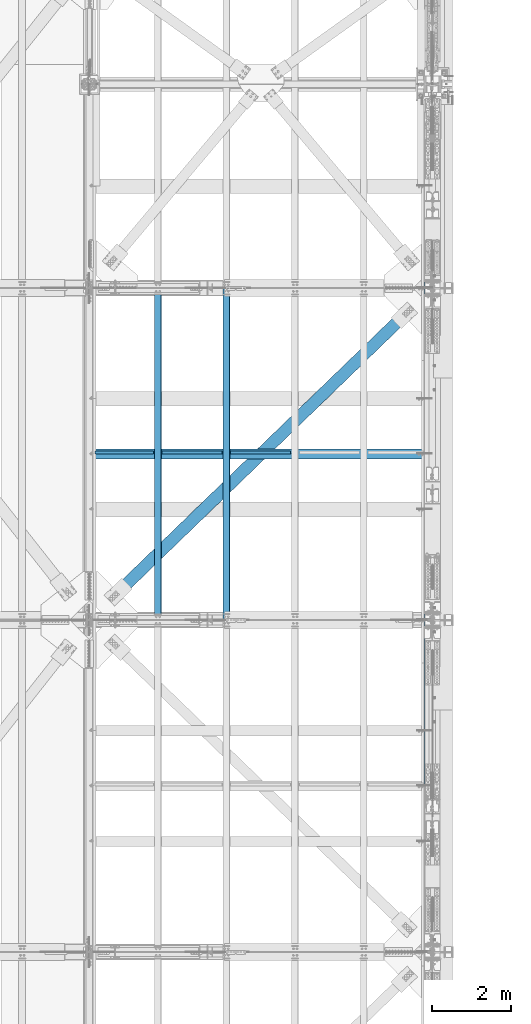
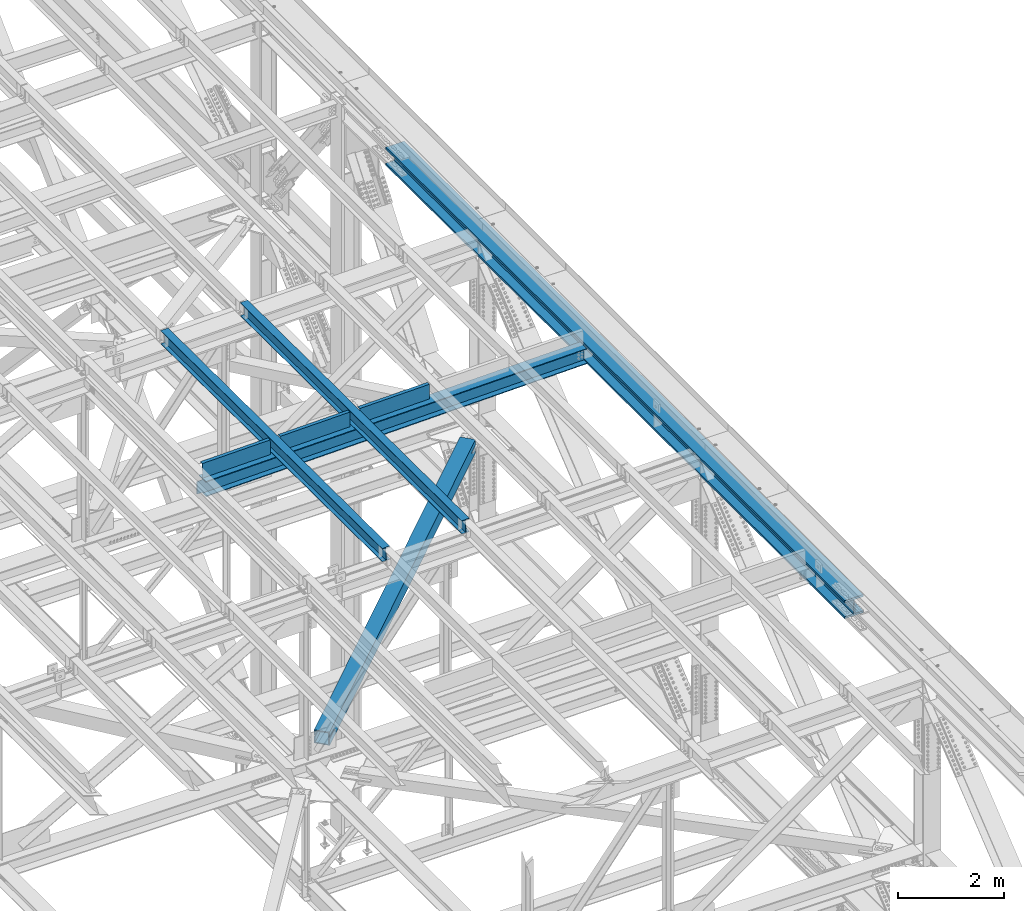
# One storey, part 1982 of 3843: 8 beams, 8 elements without a shape of their own.
"""IFC2X3 building model written with IfcOpenShell, lengths in millimetres."""

from ifc_helpers import new_model, si_unit, frame, origin_with_axes, place, context, subcontext, project, spatial, faceted_brep, material, type_object, element, aggregate, save


model = new_model("IFC2X3")

# Units and contexts
model_context = context("Model", 3, precision=1e-05, world=origin_with_axes())
body_context = subcontext(model_context, "Body", "Model", "MODEL_VIEW")
ifc_project = project(units=[si_unit("LENGTHUNIT", "METRE", prefix="MILLI"), si_unit("AREAUNIT", "SQUARE_METRE"), si_unit("VOLUMEUNIT", "CUBIC_METRE"), si_unit("MASSUNIT", "GRAM", prefix="KILO"), si_unit("TIMEUNIT", "SECOND"), si_unit("PLANEANGLEUNIT", "RADIAN"), si_unit("SOLIDANGLEUNIT", "STERADIAN"), si_unit("THERMODYNAMICTEMPERATUREUNIT", "DEGREE_CELSIUS"), si_unit("LUMINOUSINTENSITYUNIT", "LUMEN")], contexts=[model_context])

# Site, building, storey
site_placement = place(None, origin_with_axes())
site = spatial("IfcSite", under=ifc_project, at=site_placement, CompositionType="ELEMENT")
building_placement = place(site_placement, origin_with_axes())
building = spatial("IfcBuilding", under=site, at=building_placement, Name="Undefined", CompositionType="ELEMENT")
storey_placement = place(building_placement, origin_with_axes())
storey = spatial("IfcBuildingStorey", under=building, at=storey_placement, Name="Undefined", CompositionType="ELEMENT", Elevation=0.0)

# Assembly, beam
assembly_1_placement = place(storey_placement, origin_with_axes())
assembly_1 = element("IfcElementAssembly", 1, at=assembly_1_placement, inside=storey, Name="BEAM", AssemblyPlace="NOTDEFINED", PredefinedType="RIGID_FRAME")
ifc_material_1 = material(Name="STEEL/A992")
beam_type_1 = type_object("IfcBeamType", Name="W12X26", PredefinedType="NOTDEFINED")
beam_1_placement = place(assembly_1_placement, frame((80463.9094956042, 75629.3538179581, 46568.9364390304), z_axis=(-0.0211520978551998, 0.00548814400003175, 0.999761206004593), x_axis=(-2.79999995016577e-08, 0.999984933284011, -0.0054893720015587)))
beam_1 = element("IfcBeam", 2, at=beam_1_placement, type_object=beam_type_1, material=ifc_material_1, Name="BEAM", ObjectType="W12X26", context=body_context, shape_type="Brep", body=[
    faceted_brep([(12.7097787592938, 82.5500000013999, -155.574999999641), (12.6575034070993, 82.5500000013417, -146.049999999654), (8343.98302908371, 82.5499999836029, -146.049999993309), (8344.03530443589, 82.5499999836611, -155.574999993281), (12.6482846770959, 3.17500000093423, -146.049999999646), (8343.97381035371, 3.17499998316634, -146.049999993294), (11.0451738764241, 3.17499999911524, 146.049999999675), (8342.37069955299, 3.17499998134736, 146.05000000602), (11.0543926064129, 82.5499999995372, 146.049999999661), (8342.379918283, 82.5499999817839, 146.050000006013), (11.0021172542038, 82.5499999994936, 155.574999999633), (8342.32764293082, 82.5499999817257, 155.575000005985), (10.9829422958137, -82.5500000014435, 155.574999999662), (8342.3084679724, -82.5500000191823, 155.575000006014), (11.0352176479937, -82.5500000013708, 146.049999999683), (8342.36074332461, -82.5500000191096, 146.050000006042), (11.0444363780116, -3.17500000093423, 146.049999999668), (8342.36996205461, -3.17500001867302, 146.050000006027), (12.6475471787126, -3.17499999911524, -146.049999999639), (8343.9730728553, -3.17500001686858, -146.049999993294), (12.6383284487092, -82.5499999995518, -146.049999999625), (8343.96385412531, -82.5500000172906, -146.04999999328), (12.6906038008892, -82.5499999994936, -155.574999999611), (8344.0161294775, -82.5500000172469, -155.574999993252)], [[[0, 1, 2, 3]], [[1, 4, 5, 2]], [[4, 6, 7, 5]], [[6, 8, 9, 7]], [[8, 10, 11, 9]], [[10, 12, 13, 11]], [[12, 14, 15, 13]], [[14, 16, 17, 15]], [[16, 18, 19, 17]], [[18, 20, 21, 19]], [[20, 22, 23, 21]], [[22, 0, 3, 23]], [[5, 7, 9, 11, 13, 15, 17, 19, 21, 23, 3, 2]], [[22, 20, 18, 16, 14, 12, 10, 8, 6, 4, 1, 0]]]),
])
aggregate(assembly_1, [beam_1])

assembly_2_placement = place(storey_placement, origin_with_axes())
assembly_2 = element("IfcElementAssembly", 3, at=assembly_2_placement, inside=storey, Name="BEAM", AssemblyPlace="NOTDEFINED", PredefinedType="RIGID_FRAME")
beam_2_placement = place(assembly_2_placement, frame((78736.7094955792, 75629.4056891217, 46535.1810461957), z_axis=(-0.0211520977636101, 0.00582156000079706, 0.99975932013628), x_axis=(-2.8000000666196e-08, 0.999983046989539, -0.00582286299993951)))
beam_2 = element("IfcBeam", 4, at=beam_2_placement, type_object=beam_type_1, material=ifc_material_1, Name="BEAM", ObjectType="W12X26", context=body_context, shape_type="Brep", body=[
    faceted_brep([(12.7103851462743, 82.5499999995809, -155.574999999808), (12.6549338504556, 82.5499999996246, -146.049999999806), (8343.99617516747, 82.5499999821041, -146.050000004871), (8344.05162646329, 82.5499999820458, -155.575000004872), (12.6451551801292, 3.174999999188, -146.050000000025), (8343.98639649714, 3.1749999816675, -146.050000005089), (10.944648774981, 3.17500000080327, 146.050000000025), (8342.28589009201, 3.17499998329731, 146.049999994961), (10.9544274453074, 82.5500000012398, 146.050000000243), (8342.29566876232, 82.5499999837193, 146.049999995172), (10.8989761495031, 82.550000001298, 155.575000000244), (8342.2402174665, 82.5499999837775, 155.57499999518), (10.8786365152046, -82.54999999961, 155.574999999786), (8342.21987783222, -82.5500000171305, 155.574999994729), (10.9340878110379, -82.5499999996537, 146.049999999792), (8342.27532912804, -82.5500000171887, 146.049999994728), (10.9438664813642, -3.17499999921711, 146.05000000001), (8342.28510779837, -3.17500001675216, 146.049999994939), (12.6443728864979, -3.17500000083237, -146.050000000047), (8343.98561420353, -3.17500001838198, -146.050000005103), (12.634594216157, -82.5500000012835, -146.050000000265), (8343.9758355332, -82.5500000187894, -146.050000005322), (12.6900455119903, -82.5500000013271, -155.575000000259), (8344.03128682902, -82.5500000188476, -155.575000005323)], [[[0, 1, 2, 3]], [[1, 4, 5, 2]], [[4, 6, 7, 5]], [[6, 8, 9, 7]], [[8, 10, 11, 9]], [[10, 12, 13, 11]], [[12, 14, 15, 13]], [[14, 16, 17, 15]], [[16, 18, 19, 17]], [[18, 20, 21, 19]], [[20, 22, 23, 21]], [[22, 0, 3, 23]], [[5, 7, 9, 11, 13, 15, 17, 19, 21, 23, 3, 2]], [[22, 20, 18, 16, 14, 12, 10, 8, 6, 4, 1, 0]]]),
])
aggregate(assembly_2, [beam_2])

assembly_3_placement = place(storey_placement, origin_with_axes())
assembly_3 = element("IfcElementAssembly", 5, at=assembly_3_placement, inside=storey, Name="BENT_PLATE", AssemblyPlace="NOTDEFINED", PredefinedType="RIGID_FRAME")
ifc_material_2 = material(Name="STEEL/A36")
beam_type_2 = type_object("IfcBeamType", PredefinedType="NOTDEFINED")
beam_3_placement = place(assembly_3_placement, frame((77895.8502140267, 79811.5625000033, 46316.359233359), z_axis=(-0.999817430718778, 0.0, -0.0191077269946473), x_axis=(-0.0191077269946443, 0.0, 0.999817430718778)))
beam_3 = element("IfcBeam", 6, at=beam_3_placement, type_object=beam_type_2, material=ifc_material_2, Name="BENT_PLATE", context=body_context, shape_type="Brep", body=[
    faceted_brep([(2.31375452131033e-09, -4.76249999999709, -736.599999997517), (-2.30647856369615e-09, -4.76249999999709, 736.599999997474), (-2.30647856369615e-09, 4.76249999999709, 736.599999997474), (2.31375452131033e-09, 4.76249999999709, -736.599999997517), (327.024999947338, 4.76250000002619, 736.600000004051), (327.024999981979, 4.76250000002619, -736.600000004313), (336.549999981966, -4.76249999996799, -736.600000004328), (336.549999947325, -4.76249999996799, 736.600000004051), (327.024999959613, 71.4375000200889, 736.600000005245), (327.024999969712, 71.4375000446889, -736.60000000312), (336.549999959585, 71.4375000200962, 736.600000005245), (336.549999969691, 71.4375000446962, -736.600000003134)], [[[0, 1, 2, 3]], [[3, 2, 4, 5]], [[1, 0, 6, 7]], [[5, 4, 8, 9]], [[4, 2, 1, 7, 10, 8]], [[7, 6, 11, 10]], [[6, 0, 3, 5, 9, 11]], [[10, 11, 9, 8]]]),
])
aggregate(assembly_3, [beam_3])

assembly_4_placement = place(storey_placement, origin_with_axes())
assembly_4 = element("IfcElementAssembly", 7, at=assembly_4_placement, inside=storey, Name="BENT_PLATE", AssemblyPlace="NOTDEFINED", PredefinedType="RIGID_FRAME")
beam_4_placement = place(assembly_4_placement, frame((79603.8052549715, 79811.5625000034, 46349.0041236298), z_axis=(-0.999817430718778, 0.0, -0.0191077269946473), x_axis=(-0.0191077269946443, 0.0, 0.999817430718778)))
beam_4 = element("IfcBeam", 8, at=beam_4_placement, type_object=beam_type_2, material=ifc_material_2, Name="BENT_PLATE", context=body_context, shape_type="Brep", body=[
    faceted_brep([(2.38651409745216e-09, -4.76249999999709, -755.649999997448), (-2.37923813983798e-09, -4.76249999999709, 755.649999997433), (-2.37923813983798e-09, 4.76249999999709, 755.649999997433), (2.38651409745216e-09, 4.76249999999709, -755.649999997448), (327.024999945941, 4.76250000002619, 755.650000004171), (327.024999981295, 4.76250000002619, -755.650000004418), (336.549999981282, -4.76249999996799, -755.650000004447), (336.549999945928, -4.76249999996799, 755.650000004156), (327.024999958514, 71.4375000207219, 755.650000005364), (327.024999968708, 71.4375000458094, -755.650000003239), (336.549999958501, 71.4375000207219, 755.650000005349), (336.549999968687, 71.4375000458094, -755.650000003254)], [[[0, 1, 2, 3]], [[3, 2, 4, 5]], [[1, 0, 6, 7]], [[5, 4, 8, 9]], [[4, 2, 1, 7, 10, 8]], [[7, 6, 11, 10]], [[6, 0, 3, 5, 9, 11]], [[10, 11, 9, 8]]]),
])
aggregate(assembly_4, [beam_4])

assembly_5_placement = place(storey_placement, origin_with_axes())
assembly_5 = element("IfcElementAssembly", 9, at=assembly_5_placement, inside=storey, Name="BENT_PLATE", AssemblyPlace="NOTDEFINED", PredefinedType="RIGID_FRAME")
beam_5_placement = place(assembly_5_placement, frame((81330.8068169715, 79811.5625000034, 46382.6083280998), z_axis=(-0.999817430718778, 0.0, -0.0191077269946473), x_axis=(-0.0191077269946443, 0.0, 0.999817430718778)))
beam_5 = element("IfcBeam", 10, at=beam_5_placement, type_object=beam_type_2, material=ifc_material_2, Name="BENT_PLATE", context=body_context, shape_type="Brep", body=[
    faceted_brep([(2.38651409745216e-09, -4.76249999999709, -755.649999997448), (-2.37923813983798e-09, -4.76249999999709, 755.649999997433), (-2.37923813983798e-09, 4.76249999999709, 755.649999997433), (2.38651409745216e-09, 4.76249999999709, -755.649999997448), (327.024999945941, 4.76250000002619, 755.650000004171), (327.024999981295, 4.76250000002619, -755.650000004418), (336.549999981282, -4.76249999996799, -755.650000004447), (336.549999945928, -4.76249999996799, 755.650000004156), (327.024999958514, 71.4375000207219, 755.650000005364), (327.024999968708, 71.4375000458094, -755.650000003239), (336.549999958501, 71.4375000207219, 755.650000005349), (336.549999968687, 71.4375000458094, -755.650000003254)], [[[0, 1, 2, 3]], [[3, 2, 4, 5]], [[1, 0, 6, 7]], [[5, 4, 8, 9]], [[4, 2, 1, 7, 10, 8]], [[7, 6, 11, 10]], [[6, 0, 3, 5, 9, 11]], [[10, 11, 9, 8]]]),
])
aggregate(assembly_5, [beam_5])

assembly_6_placement = place(storey_placement, origin_with_axes())
assembly_6 = element("IfcElementAssembly", 11, at=assembly_6_placement, inside=storey, Name="BEAM", AssemblyPlace="NOTDEFINED", PredefinedType="RIGID_FRAME")
beam_type_3 = type_object("IfcBeamType", Name="W14X257", PredefinedType="NOTDEFINED")
beam_6_placement = place(assembly_6_placement, frame((85648.8, 70014.7142968034, 46314.5491930665), z_axis=(0.0, 0.00329764299921226, 0.999994562760543), x_axis=(0.0, 0.999994562760543, -0.00329764299921044)))
beam_6 = element("IfcBeam", 12, at=beam_6_placement, type_object=beam_type_3, material=ifc_material_1, Name="BEAM", ObjectType="W14X257", context=body_context, shape_type="Brep", body=[
    faceted_brep([(13817.3349582041, -203.199999999997, 164.32508028848), (13817.3349582041, -15.0812500000029, 164.32508028848), (15544.5303172543, -15.0812500000029, 162.580440755861), (15544.5303172543, -203.199999999997, 162.580440755861), (12090.1391675801, -203.199999999997, 165.571251487934), (12090.1391675801, -15.0812500000029, 165.571251487934), (10362.9430892403, -203.199999999997, 166.318954250833), (10362.9430892403, -15.0812500000029, 166.318954250833), (8635.74686704262, -203.199999999997, 166.568188513855), (8635.74686704262, -15.0812500000029, 166.568188513855), (6908.5506448449, -203.199999999997, 166.318954257426), (6908.5506448449, -15.0812500000029, 166.318954257426), (5181.35456650514, -203.199999999997, 165.571251501126), (5181.35456650514, -15.0812500000029, 165.571251501126), (3454.15877588118, -203.199999999997, 164.325080308277), (3454.15877588118, -15.0812500000029, 164.325080308277), (1726.96341683094, -203.199999999997, 162.580440782258), (1726.96341683094, -15.0812500000029, 162.580440782258), (6.11862910160562, -203.199999999997, 160.345579806541), (6.11862910160562, -15.0812500000029, 160.345579806541), (13817.3349582041, 15.0812500000029, 164.32508028848), (13817.3349582041, 203.199999999997, 164.32508028848), (15544.5303172543, 203.199999999997, 162.580440755861), (15544.5303172543, 15.0812500000029, 162.580440755861), (12090.1391675801, 15.0812500000029, 165.571251487934), (12090.1391675801, 203.199999999997, 165.571251487934), (10362.9430892403, 15.0812500000029, 166.318954250833), (10362.9430892403, 203.199999999997, 166.318954250833), (8635.74686704262, 15.0812500000029, 166.568188513855), (8635.74686704262, 203.199999999997, 166.568188513855), (6908.5506448449, 15.0812500000029, 166.318954257426), (6908.5506448449, 203.199999999997, 166.318954257426), (5181.35456650514, 15.0812500000029, 165.571251501126), (5181.35456650514, 203.199999999997, 165.571251501126), (3454.15877588118, 15.0812500000029, 164.325080308277), (3454.15877588118, 203.199999999997, 164.325080308277), (1726.96341683094, 15.0812500000029, 162.580440782258), (1726.96341683094, 203.199999999997, 162.580440782258), (6.11862910160562, 15.0812500000029, 160.345579806541), (6.11862910160562, 203.199999999997, 160.345579806541), (13817.0573179999, 203.199999999997, -156.349799519972), (13817.0573179999, 15.0812500000029, -156.349799519972), (15544.1601303508, 15.0812500000029, -158.094345571204), (15544.1601303508, 203.199999999997, -158.094345571204), (12089.9540740984, 203.199999999997, -155.103695092948), (12089.9540740984, 15.0812500000029, -155.103695092948), (10362.8505424965, 203.199999999997, -154.356032393509), (10362.8505424965, 15.0812500000029, -154.356032393509), (8635.74686704433, 203.199999999997, -154.106811484977), (8635.74686704433, 15.0812500000029, -154.106811484977), (6908.64319159219, 203.199999999997, -154.356032386917), (6908.64319159219, 15.0812500000029, -154.356032386917), (5181.53965999027, 203.199999999997, -155.10369507975), (5181.53965999027, 15.0812500000029, -155.10369507975), (3454.43641608878, 203.199999999997, -156.349799500167), (3454.43641608878, 15.0812500000029, -156.349799500167), (1727.33360373788, 203.199999999997, -158.094345544807), (1727.33360373788, 15.0812500000029, -158.094345544807), (6.58136037488293, 203.199999999997, -160.329086333157), (6.58136037488293, 15.0812500000029, -160.329086333157), (13817.0160843062, -203.199999999997, -203.974781669742), (13817.0160843062, 203.199999999997, -203.974781669742), (15544.1051520978, 203.199999999997, -205.719313837588), (15544.1051520978, -203.199999999997, -205.719313837588), (12089.9265849674, -203.199999999997, -202.728687159419), (12089.9265849674, 203.199999999997, -202.728687159419), (10362.8367979305, -203.199999999997, -201.981030409996), (10362.8367979305, 203.199999999997, -201.981030409996), (8635.74686704458, -203.199999999997, -201.731811484802), (8635.74686704458, 203.199999999997, -201.731811484802), (6908.65693615862, -203.199999999997, -201.981030403396), (6908.65693615862, 203.199999999997, -201.981030403396), (5181.56714912175, -203.199999999997, -202.72868714622), (5181.56714912175, 203.199999999997, -202.72868714622), (3454.47764978299, -203.199999999997, -203.974781649944), (3454.47764978299, 203.199999999997, -203.974781649944), (1727.3885819914, -203.199999999997, -205.719313811198), (1727.3885819914, 203.199999999997, -205.719313811198), (6.65008284120995, -203.199999999997, -207.95403674995), (6.65008284120995, 203.199999999997, -207.95403674995), (13817.0573179999, -15.0812500000029, -156.349799519972), (13817.0573179999, -203.199999999997, -156.349799519972), (15544.1601303508, -203.199999999997, -158.094345571204), (15544.1601303508, -15.0812500000029, -158.094345571204), (12089.9540740984, -15.0812500000029, -155.103695092948), (12089.9540740984, -203.199999999997, -155.103695092948), (10362.8505424965, -15.0812500000029, -154.356032393509), (10362.8505424965, -203.199999999997, -154.356032393509), (8635.74686704433, -15.0812500000029, -154.106811484977), (8635.74686704433, -203.199999999997, -154.106811484977), (6908.64319159219, -15.0812500000029, -154.356032386917), (6908.64319159219, -203.199999999997, -154.356032386917), (5181.53965999027, -15.0812500000029, -155.10369507975), (5181.53965999027, -203.199999999997, -155.10369507975), (3454.43641608878, -15.0812500000029, -156.349799500167), (3454.43641608878, -203.199999999997, -156.349799500167), (1727.33360373788, -15.0812500000029, -158.094345544807), (1727.33360373788, -203.199999999997, -158.094345544807), (6.58136037488293, -15.0812500000029, -160.329086333157), (6.58136037488293, -203.199999999997, -160.329086333157), (6.04990663529315, -203.199999999997, 207.970530223327), (6.04990663529315, 203.199999999997, 207.970530223327), (1726.90843857745, -203.199999999997, 210.205409048656), (1726.90843857745, 203.199999999997, 210.205409048656), (3454.11754218697, -203.199999999997, 211.950062458054), (3454.11754218697, 203.199999999997, 211.950062458054), (5181.32707737367, -203.199999999997, 213.196243567589), (5181.32707737367, 203.199999999997, 213.196243567589), (6908.53690027847, -203.199999999997, 213.943952273912), (6908.53690027847, 203.199999999997, 213.943952273912), (8635.74686704236, -203.199999999997, 214.193188513673), (8635.74686704236, 203.199999999997, 214.193188513673), (10362.9568338062, -203.199999999997, 213.94395226732), (10362.9568338062, 203.199999999997, 213.94395226732), (12090.1666567111, -203.199999999997, 213.196243554397), (12090.1666567111, 203.199999999997, 213.196243554397), (13817.3761918978, -203.199999999997, 211.950062438249), (13817.3761918978, 203.199999999997, 211.950062438249), (15544.5852955073, -203.199999999997, 210.205409022252), (15544.5852955073, 203.199999999997, 210.205409022252), (17265.4438341366, -203.199999999997, 207.970530181665), (17265.4438341366, 203.199999999997, 207.970530181665), (17265.374987089, 203.199999999997, 160.345579926674), (17265.374987089, 15.0812500000029, 160.345579926674), (17264.9114169685, 15.0812500000029, -160.329085123609), (17264.9114169685, 203.199999999997, -160.329085123609), (17264.8425699209, 203.199999999997, -207.954035378607), (17264.8425699209, -203.199999999997, -207.954035378607), (17264.9114169685, -203.199999999997, -160.329085123609), (17264.9114169685, -15.0812500000029, -160.329085123609), (17265.374987089, -15.0812500000029, 160.345579926674), (17265.374987089, -203.199999999997, 160.345579926674)], [[[0, 1, 2, 3]], [[4, 5, 1, 0]], [[6, 7, 5, 4]], [[8, 9, 7, 6]], [[10, 11, 9, 8]], [[12, 13, 11, 10]], [[14, 15, 13, 12]], [[16, 17, 15, 14]], [[17, 16, 18, 19]], [[20, 21, 22, 23]], [[24, 25, 21, 20]], [[26, 27, 25, 24]], [[28, 29, 27, 26]], [[30, 31, 29, 28]], [[32, 33, 31, 30]], [[34, 35, 33, 32]], [[36, 37, 35, 34]], [[37, 36, 38, 39]], [[40, 41, 42, 43]], [[44, 45, 41, 40]], [[46, 47, 45, 44]], [[48, 49, 47, 46]], [[50, 51, 49, 48]], [[52, 53, 51, 50]], [[54, 55, 53, 52]], [[56, 57, 55, 54]], [[57, 56, 58, 59]], [[60, 61, 62, 63]], [[64, 65, 61, 60]], [[66, 67, 65, 64]], [[68, 69, 67, 66]], [[70, 71, 69, 68]], [[72, 73, 71, 70]], [[74, 75, 73, 72]], [[76, 77, 75, 74]], [[77, 76, 78, 79]], [[80, 81, 82, 83]], [[84, 85, 81, 80]], [[86, 87, 85, 84]], [[88, 89, 87, 86]], [[90, 91, 89, 88]], [[92, 93, 91, 90]], [[94, 95, 93, 92]], [[96, 97, 95, 94]], [[97, 96, 98, 99]], [[19, 18, 100, 101, 39, 38, 59, 58, 79, 78, 99, 98]], [[102, 103, 101, 100]], [[103, 102, 104, 105]], [[105, 104, 106, 107]], [[107, 106, 108, 109]], [[109, 108, 110, 111]], [[111, 110, 112, 113]], [[113, 112, 114, 115]], [[115, 114, 116, 117]], [[117, 116, 118, 119]], [[119, 118, 120, 121]], [[22, 21, 25, 27, 29, 31, 33, 35, 37, 39, 101, 103, 105, 107, 109, 111, 113, 115, 117, 119, 121, 122]], [[23, 22, 122, 123]], [[42, 41, 45, 47, 49, 51, 53, 55, 57, 59, 38, 36, 34, 32, 30, 28, 26, 24, 20, 23, 123, 124]], [[43, 42, 124, 125]], [[62, 61, 65, 67, 69, 71, 73, 75, 77, 79, 58, 56, 54, 52, 50, 48, 46, 44, 40, 43, 125, 126]], [[63, 62, 126, 127]], [[82, 81, 85, 87, 89, 91, 93, 95, 97, 99, 78, 76, 74, 72, 70, 68, 66, 64, 60, 63, 127, 128]], [[83, 82, 128, 129]], [[2, 1, 5, 7, 9, 11, 13, 15, 17, 19, 98, 96, 94, 92, 90, 88, 86, 84, 80, 83, 129, 130]], [[3, 2, 130, 131]], [[118, 116, 114, 112, 110, 108, 106, 104, 102, 100, 18, 16, 14, 12, 10, 8, 6, 4, 0, 3, 131, 120]], [[130, 129, 128, 127, 126, 125, 124, 123, 122, 121, 120, 131]]]),
])
aggregate(assembly_6, [beam_6])

assembly_7_placement = place(storey_placement, origin_with_axes())
assembly_7 = element("IfcElementAssembly", 13, at=assembly_7_placement, inside=storey, AssemblyPlace="NOTDEFINED", PredefinedType="RIGID_FRAME")
ifc_material_3 = material()
beam_type_4 = type_object("IfcBeamType", Name="HSS12X12X3/4", PredefinedType="NOTDEFINED")
beam_7_placement = place(assembly_7_placement, frame((77012.800003582, 75628.5000028864, 42246.55), z_axis=(0.695386218410511, -0.718636213424239, 0.0), x_axis=(0.718636212924514, 0.695386218926945, 0.0)))
beam_7 = element("IfcBeam", 14, at=beam_7_placement, type_object=beam_type_4, material=ifc_material_3, ObjectType="HSS12X12X3/4", context=body_context, shape_type="Brep", body=[
    faceted_brep([(10999.1862260432, 26.9875000000029, 152.399999948059), (10746.7737266535, 26.9875000000029, 152.399999949274), (10746.7737266534, 26.9875000000029, 133.349999949206), (10999.1862260432, 26.9875000000029, 133.349999947998), (10741.3061369675, 25.8999287917177, 152.399999949296), (10741.3061369674, 25.8999287917177, 133.349999949221), (10736.6709382474, 22.8027880244772, 152.399999949311), (10736.6709382473, 22.8027880244772, 133.34999994925), (10733.5737974801, 18.1675893044303, 152.39999994934), (10733.5737974801, 18.1675893044303, 133.349999949271), (10732.4862262719, 12.6999996185332, 152.399999949347), (10732.4862262718, 12.6999996185332, 133.349999949271), (10733.5737974801, 7.23241069557844, 152.39999994934), (10733.5737974801, 7.23241069557844, 133.349999949271), (10736.6709382474, 2.59721197553154, 152.399999949311), (10736.6709382473, 2.59721197553154, 133.34999994925), (10741.3061369675, -0.499928791708953, 152.399999949296), (10741.3061369674, -0.499928791708953, 133.349999949221), (10746.7737266535, -1.58749999999418, 152.399999949274), (10746.7737266534, -1.58749999999418, 133.349999949206), (10999.1862260432, -1.58749999999418, 152.399999948059), (10999.1862260432, -1.58749999999418, 133.349999947998), (10999.1862260432, 26.9875000000029, -133.350000052945), (10746.7737266521, 26.9875000000029, -133.350000051737), (10746.773726652, 26.9875000000029, -152.400000051798), (10999.1862260432, 26.9875000000029, -152.400000052999), (10741.3061369661, 25.8999287917177, -133.350000051708), (10741.3061369661, 25.8999287917177, -152.400000051769), (10736.6709382461, 22.8027880244772, -133.350000051686), (10736.670938246, 22.8027880244772, -152.400000051762), (10733.5737974788, 18.1675893044303, -133.350000051679), (10733.5737974787, 18.1675893044303, -152.40000005174), (10732.4862262705, 12.6999996185332, -133.350000051671), (10732.4862262704, 12.6999996185332, -152.400000051733), (10733.5737974788, 7.23241069557844, -133.350000051679), (10733.5737974787, 7.23241069557844, -152.40000005174), (10736.6709382461, 2.59721197553154, -133.350000051686), (10736.670938246, 2.59721197553154, -152.400000051762), (10741.3061369661, -0.499928791708953, -133.350000051708), (10741.3061369661, -0.499928791708953, -152.400000051769), (10746.7737266521, -1.58749999999418, -133.350000051737), (10746.773726652, -1.58749999999418, -152.400000051798), (10999.1862260432, -1.58749999999418, -133.350000052945), (10999.1862260432, -1.58749999999418, -152.400000052999), (1326.70066549764, -0.49930169347499, -133.350000006808), (1326.70066548402, -0.49930169347499, -152.400000006869), (1321.23307579808, -1.58687290176022, -152.400000006847), (1321.2330758117, -1.58687290176022, -133.350000006786), (1331.33586421773, 2.5978390737655, -133.35000000683), (1331.33586420411, 2.5978390737655, -152.400000006898), (1334.433004985, 7.2330377938124, -133.350000006837), (1334.43300497139, 7.2330377938124, -152.400000006905), (1335.5205761933, 12.7006267167671, -133.350000006837), (1335.52057617968, 12.7006267167671, -152.400000006913), (1334.433004985, 18.1682164026643, -133.350000006837), (1334.43300497139, 18.1682164026643, -152.400000006905), (1331.33586421773, 22.8034151227112, -133.35000000683), (1331.33586420411, 22.8034151227112, -152.400000006898), (1326.70066549764, 25.9005558899516, -133.350000006808), (1326.70066548402, 25.9005558899516, -152.400000006869), (1321.2330758117, 26.9881270982369, -133.350000006786), (1321.23307579808, 26.9881270982369, -152.400000006847), (1018.02056396882, 26.9881270982369, -133.350000005331), (1018.02056395514, 26.9881270982369, -152.400000005399), (10999.1862260432, -152.400000000001, -152.400000052999), (1018.02056852015, -152.400000000001, -152.399999995658), (1018.02056395514, -1.58687290176022, -152.400000005399), (1018.02056852015, 152.400000000001, -152.399999995658), (10999.1862260432, 152.400000000001, -152.400000052999), (1018.02056396882, -1.58687290176022, -133.350000005331), (10999.1862260432, -133.349999999999, 133.349999947998), (10999.1862260432, -133.349999999999, -133.350000052945), (1018.02056852025, -133.349999999999, -133.349999995713), (1018.02056852159, -133.349999999999, 133.350000003455), (10999.1862260432, 133.349999999999, -133.350000052945), (1018.02056852025, 133.349999999999, -133.349999995713), (10999.1862260432, 133.349999999999, 133.349999947998), (1018.02056852159, 133.349999999999, 133.350000003455), (1326.70066570192, -0.49930169347499, 152.399999994203), (1326.7006656883, -0.49930169347499, 133.349999994135), (1321.23307600235, -1.58687290176022, 133.349999994157), (1321.23307601597, -1.58687290176022, 152.399999994225), (1331.33586442198, 2.5978390737655, 152.399999994174), (1331.33586440836, 2.5978390737655, 133.349999994113), (1334.43300518928, 7.2330377938124, 152.399999994174), (1334.43300517564, 7.2330377938124, 133.349999994099), (1335.52057639755, 12.7006267167671, 152.399999994167), (1335.52057638395, 12.7006267167671, 133.349999994091), (1334.43300518928, 18.1682164026643, 152.399999994174), (1334.43300517564, 18.1682164026643, 133.349999994099), (1331.33586442198, 22.8034151227112, 152.399999994174), (1331.33586440836, 22.8034151227112, 133.349999994113), (1326.70066570192, 25.9005558899516, 152.399999994203), (1326.7006656883, 25.9005558899516, 133.349999994135), (1321.23307601597, 26.9881270982369, 152.399999994225), (1321.23307600235, 26.9881270982369, 133.349999994157), (1018.02056417418, 26.9881270982369, 152.399999995673), (1018.0205641605, 26.9881270982369, 133.349999995605), (1018.02056852169, 152.400000000001, 152.400000003399), (10999.1862260432, 152.400000000001, 152.399999948059), (1018.0205641605, -1.58687290176022, 133.349999995605), (1018.02056417418, -1.58687290176022, 152.399999995673), (1018.02056852169, -152.400000000001, 152.400000003399), (10999.1862260432, -152.400000000001, 152.399999948059)], [[[0, 1, 2, 3]], [[4, 5, 2, 1]], [[6, 7, 5, 4]], [[8, 9, 7, 6]], [[10, 11, 9, 8]], [[12, 13, 11, 10]], [[14, 15, 13, 12]], [[16, 17, 15, 14]], [[18, 19, 17, 16]], [[20, 21, 19, 18]], [[22, 23, 24, 25]], [[26, 27, 24, 23]], [[28, 29, 27, 26]], [[30, 31, 29, 28]], [[32, 33, 31, 30]], [[34, 35, 33, 32]], [[36, 37, 35, 34]], [[38, 39, 37, 36]], [[40, 41, 39, 38]], [[42, 43, 41, 40]], [[44, 45, 46, 47]], [[48, 49, 45, 44]], [[50, 51, 49, 48]], [[52, 53, 51, 50]], [[54, 55, 53, 52]], [[56, 57, 55, 54]], [[58, 59, 57, 56]], [[60, 61, 59, 58]], [[62, 63, 61, 60]], [[64, 65, 66, 46, 45, 49, 51, 53, 55, 57, 59, 61, 63, 67, 68, 25, 24, 27, 29, 31, 33, 35, 37, 39, 41, 43]], [[47, 46, 66, 69]], [[70, 71, 72, 73]], [[38, 36, 34, 32, 30, 28, 26, 23, 22, 74, 75, 62, 60, 58, 56, 54, 52, 50, 48, 44, 47, 69, 72, 71, 42, 40]], [[74, 76, 77, 75]], [[78, 79, 80, 81]], [[82, 83, 79, 78]], [[84, 85, 83, 82]], [[86, 87, 85, 84]], [[88, 89, 87, 86]], [[90, 91, 89, 88]], [[92, 93, 91, 90]], [[94, 95, 93, 92]], [[96, 97, 95, 94]], [[98, 67, 63, 62, 75, 77, 97, 96]], [[99, 68, 67, 98]], [[76, 74, 22, 25, 68, 99, 0, 3]], [[70, 73, 100, 80, 79, 83, 85, 87, 89, 91, 93, 95, 97, 77, 76, 3, 2, 5, 7, 9, 11, 13, 15, 17, 19, 21]], [[81, 80, 100, 101]], [[73, 72, 69, 66, 65, 102, 101, 100]], [[64, 103, 102, 65]], [[16, 14, 12, 10, 8, 6, 4, 1, 0, 99, 98, 96, 94, 92, 90, 88, 86, 84, 82, 78, 81, 101, 102, 103, 20, 18]], [[103, 64, 43, 42, 71, 70, 21, 20]]]),
])
aggregate(assembly_7, [beam_7])

assembly_8_placement = place(storey_placement, origin_with_axes())
assembly_8 = element("IfcElementAssembly", 15, at=assembly_8_placement, inside=storey, Name="BEAM", AssemblyPlace="NOTDEFINED", PredefinedType="RIGID_FRAME")
beam_type_5 = type_object("IfcBeamType", Name="W14X61", PredefinedType="NOTDEFINED")
beam_8_placement = place(assembly_8_placement, frame((77012.7999994625, 79806.8, 46123.2669268797), z_axis=(-0.0191089640014834, 0.0, 0.999817407077307), x_axis=(0.999817407077307, 0.0, 0.0191089640014779)))
beam_8 = element("IfcBeam", 16, at=beam_8_placement, type_object=beam_type_5, material=ifc_material_1, Name="BEAM", ObjectType="W14X61", context=body_context, shape_type="Brep", body=[
    faceted_brep([(15.4985517516616, -4.76249999999709, -144.462499984227), (15.4985517516616, 4.76249999999709, -144.462499984227), (129.191731535015, 4.76249999999709, -144.462499984482), (129.191731535015, -4.76249999999709, -144.462499984482), (134.051811053068, 4.76249999999709, -145.42922990708), (134.051811053068, -4.76249999999709, -145.42922990708), (138.171987521244, 4.76249999999709, -148.182243807583), (138.171987521244, -4.76249999999709, -148.182243807583), (140.92500142171, 4.76249999999709, -152.302420275766), (140.92500142171, -4.76249999999709, -152.302420275766), (141.89173134428, -4.76249999999709, -157.162499793827), (141.89173134428, 4.76249999999709, -157.162499793827), (141.891731344294, 4.76249999999709, -160.337500000533), (141.891731344294, 127.0, -160.337500000533), (141.891731344251, 127.0, -176.212500000569), (141.891731344251, -127.0, -176.212500000569), (141.891731344294, -127.0, -160.337500000533), (141.891731344294, -4.76249999999709, -160.337500000533), (8418.2698977901, -127.0, 160.33749997618), (8418.26989778999, -127.0, 176.21249997618), (141.891731345037, -127.0, 176.212499999958), (141.891731344993, -127.0, 160.337499999929), (8418.26989778999, 127.0, 176.21249997618), (141.891731345037, 127.0, 176.212499999958), (8418.2698977901, 127.0, 160.33749997618), (141.891731344993, 127.0, 160.337499999929), (8418.2698977901, 4.76249999999709, 160.33749997618), (141.891731344993, 4.76249999999709, 160.337499999929), (129.191731535626, -4.76249999999709, 144.462500016787), (129.191731535626, 4.76249999999709, 144.462500016787), (21.0206174659397, 4.76249999999709, 144.462500017027), (21.0206174659397, -4.76249999999709, 144.462500017027), (134.051811053709, -4.76249999999709, 145.429229939371), (134.051811053709, 4.76249999999709, 145.429229939371), (138.171987521884, -4.76249999999709, 148.182243839845), (138.171987521884, 4.76249999999709, 148.182243839845), (140.92500142238, -4.76249999999709, 152.302420308013), (140.92500142238, 4.76249999999709, 152.302420308013), (141.891731344993, -4.76249999999709, 157.162499826074), (141.891731344993, 4.76249999999709, 157.162499826074), (141.891731344993, -4.76249999999709, 160.337499999929), (8418.2698977901, -4.76249999999709, 160.33749997618), (8418.26989779246, 4.76249999999709, -160.337500023721), (8418.26989779246, -4.76249999999709, -160.337500023721), (8418.26989779246, -127.0, -160.337500023721), (8418.26989779258, -127.0, -176.212500023721), (8418.26989779258, 127.0, -176.212500023721), (8418.26989779246, 127.0, -160.337500023721), (16.5041890335851, 4.76249999999709, -91.8456412372252), (20.9107161323336, 4.76249999999709, 138.712252835481)], [[[0, 1, 2, 3]], [[3, 2, 4, 5]], [[5, 4, 6, 7]], [[7, 6, 8, 9]], [[10, 11, 12, 13, 14, 15, 16, 17]], [[9, 8, 11, 10]], [[18, 19, 20, 21]], [[19, 22, 23, 20]], [[22, 24, 25, 23]], [[24, 26, 27, 25]], [[28, 29, 30, 31]], [[32, 33, 29, 28]], [[34, 35, 33, 32]], [[36, 37, 35, 34]], [[38, 39, 37, 36]], [[20, 23, 25, 27, 39, 38, 40, 21]], [[41, 18, 21, 40]], [[42, 26, 24, 22, 19, 18, 41, 43, 44, 45, 46, 47]], [[44, 43, 17, 16]], [[45, 44, 16, 15]], [[46, 45, 15, 14]], [[47, 46, 14, 13]], [[42, 47, 13, 12]], [[6, 4, 2, 1, 48, 49, 30, 29, 33, 35, 37, 39, 27, 26, 42, 12, 11, 8]], [[31, 30, 49, 48, 1, 0]], [[43, 41, 40, 38, 36, 34, 32, 28, 31, 0, 3, 5, 7, 9, 10, 17]]]),
])
aggregate(assembly_8, [beam_8])

save(model, "model.ifc")
